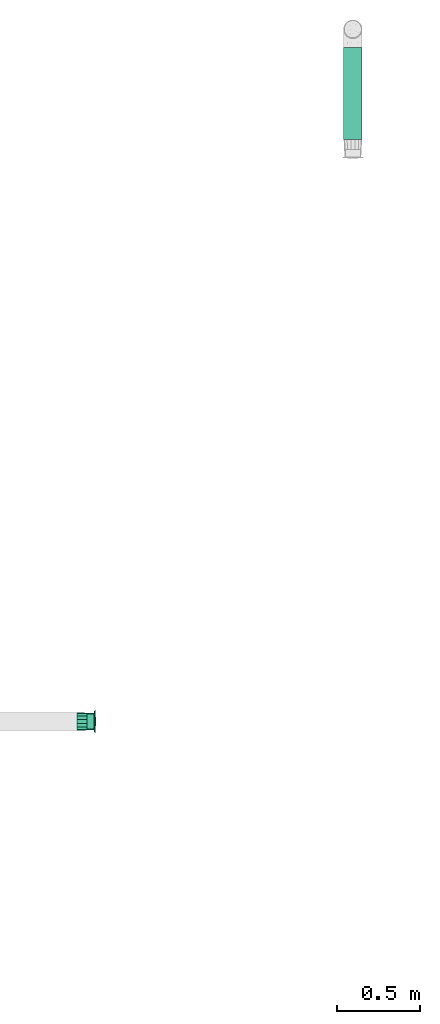
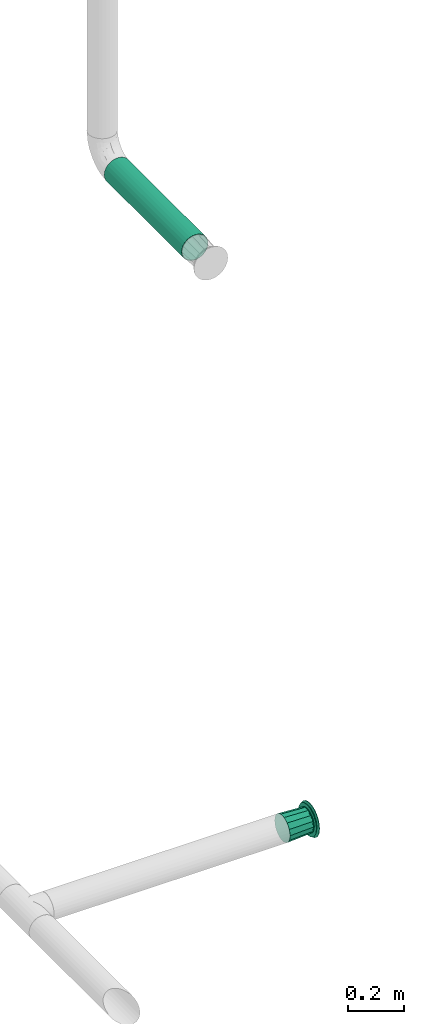
# One storey, part 110 of 115: 1 flow fitting, 1 flow segment, 1 flow terminal.
"""IFC2X3 building model written with IfcOpenShell, lengths in millimetres."""

import ifcopenshell
import ifcopenshell.guid

model = None  # the IFC model being written
_history = None  # IfcOwnerHistory: only IFC2X3 demands one
_inside = {}  # id of a spatial element -> (the spatial element, [elements in it])
_under = {}  # id of a project, library or spatial element -> (it, [spatial elements below it])
_declared = {}  # id of a project -> (the project, [libraries it declares])
_typed = {}  # id of a type object -> (the type object, [elements of that type])
_made_of = {}  # id of a material, layer set ... -> (it, [elements and type objects made of it])


def new_model(schema):
    """Start an empty IFC model of exactly this schema.

    Asked for "IFC4X3", IfcOpenShell would pick the latest addendum, in which some entities
    have other attributes; the version numbers below select the first issue.
    IFC2X3 requires an IfcOwnerHistory on every rooted entity: one is made here for all.
    """
    global model, _history
    if schema == "IFC4X3":
        model = ifcopenshell.file(schema_version=(4, 3, 0, 0))
    else:
        model = ifcopenshell.file(schema=schema)
    _inside.clear()
    _under.clear()
    _declared.clear()
    _typed.clear()
    _made_of.clear()
    _history = None
    if model.schema == "IFC2X3":
        org = make("IfcOrganization", Name="unknown")
        user = make(
            "IfcPersonAndOrganization",
            ThePerson=make("IfcPerson", FamilyName="unknown"),
            TheOrganization=org,
        )
        app = make(
            "IfcApplication",
            ApplicationDeveloper=org,
            Version="unknown",
            ApplicationFullName="unknown",
            ApplicationIdentifier="unknown",
        )
        _history = make(
            "IfcOwnerHistory",
            OwningUser=user,
            OwningApplication=app,
            ChangeAction="ADDED",
            CreationDate=0,
        )
    return model


def make(cls, **values):
    """One entity of the class cls with the attributes given. An attribute that is None is left unset."""
    return model.create_entity(
        cls, **{name: value for name, value in values.items() if value is not None}
    )


def entity(cls, *values):
    """Any entity or typed value of the class cls, its attributes in the order of the schema. None: left unset."""
    e = model.create_entity(cls)
    for i, value in enumerate(values):
        if value is not None:
            e[i] = value
    return e


def rooted(cls, **values):
    """An entity with a GlobalId (a new one), such as an element, a storey or a relation."""
    return make(cls, GlobalId=ifcopenshell.guid.new(), OwnerHistory=_history, **values)


def si_unit(unit_type, name, prefix=None):
    """IfcSIUnit, for example si_unit("LENGTHUNIT", "METRE", prefix="MILLI")."""
    return make("IfcSIUnit", UnitType=unit_type, Prefix=prefix, Name=name)


def converted_unit(unit_type, name, factor, base, dimensions=None, offset=None):
    """IfcConversionBasedUnit, such as the inch: factor (a typed value) times the base unit."""
    return make(
        "IfcConversionBasedUnit"
        if offset is None
        else "IfcConversionBasedUnitWithOffset",
        ConversionOffset=offset,
        Dimensions=None
        if dimensions is None
        else entity("IfcDimensionalExponents", *dimensions),
        UnitType=unit_type,
        Name=name,
        ConversionFactor=make(
            "IfcMeasureWithUnit", ValueComponent=factor, UnitComponent=base
        ),
    )


def derived_unit(unit_type, elements):
    """IfcDerivedUnit: a product of units, each with its exponent."""
    return make(
        "IfcDerivedUnit",
        Elements=[
            make("IfcDerivedUnitElement", Unit=unit, Exponent=power)
            for unit, power in elements
        ],
        UnitType=unit_type,
    )


def assignment(units):
    """IfcUnitAssignment: the units of a project."""
    return None if units is None else make("IfcUnitAssignment", Units=units)


def point(xyz):
    """IfcCartesianPoint."""
    return None if xyz is None else make("IfcCartesianPoint", Coordinates=xyz)


def direction(xyz):
    """IfcDirection."""
    return None if xyz is None else make("IfcDirection", DirectionRatios=xyz)


def frame(location, z_axis=None, x_axis=None):
    """IfcAxis2Placement3D, a coordinate frame: its origin and axes. An axis left out is left unset."""
    return make(
        "IfcAxis2Placement3D",
        Location=point(location),
        Axis=direction(z_axis),
        RefDirection=direction(x_axis),
    )


def frame_2d(location, x_axis=None):
    """IfcAxis2Placement2D, a coordinate frame in the plane: its origin and x axis."""
    return make(
        "IfcAxis2Placement2D", Location=point(location), RefDirection=direction(x_axis)
    )


def origin_with_axes():
    """The frame at (0, 0, 0) with the z axis (0, 0, 1) and the x axis (1, 0, 0) written out."""
    return frame((0.0, 0.0, 0.0), z_axis=(0.0, 0.0, 1.0), x_axis=(1.0, 0.0, 0.0))


def origin_2d_with_axis():
    """The frame at (0, 0) in the plane with the x axis (1, 0) written out."""
    return frame_2d((0.0, 0.0), x_axis=(1.0, 0.0))


def place(relative_to, where):
    """IfcLocalPlacement: puts the frame where relative to a parent placement (None: the world)."""
    return make(
        "IfcLocalPlacement", PlacementRelTo=relative_to, RelativePlacement=where
    )


def context(
    kind, dimensions, precision=None, world=None, true_north=None, identifier=None
):
    """IfcGeometricRepresentationContext, for example the 3D "Model" context."""
    return make(
        "IfcGeometricRepresentationContext",
        ContextIdentifier=identifier,
        ContextType=kind,
        CoordinateSpaceDimension=dimensions,
        Precision=precision,
        WorldCoordinateSystem=world,
        TrueNorth=true_north,
    )


def subcontext(parent, identifier, kind, view, scale=None):
    """IfcGeometricRepresentationSubContext, for example "Body" below "Model"."""
    return make(
        "IfcGeometricRepresentationSubContext",
        ContextIdentifier=identifier,
        ContextType=kind,
        ParentContext=parent,
        TargetScale=scale,
        TargetView=view,
    )


def project(units=None, contexts=None):
    """IfcProject with its units and contexts."""
    return rooted(
        "IfcProject",
        Name="project",
        RepresentationContexts=contexts,
        UnitsInContext=assignment(units),
    )


def spatial(cls, under=None, at=None, **own):
    """A site, building, storey or space (cls), placed at a placement, below another one or the project."""
    s = rooted(cls, ObjectPlacement=at, **own)
    if under is not None:
        _under.setdefault(under.id(), (under, []))[1].append(s)
    return s


def profile(cls, at=None, kind="AREA", **sizes):
    """A parametric profile (cls). Its sizes go by their IFC names, for example OverallWidth=200.0."""
    return make(cls, ProfileType=kind, Position=at, **sizes)


def hollow_circle(**sizes):
    """IfcCircleHollowProfileDef."""
    return profile("IfcCircleHollowProfileDef", **sizes)


def extrude(swept, where, along, depth):
    """IfcExtrudedAreaSolid: the profile swept, set in the frame where, extruded along a direction by depth."""
    return make(
        "IfcExtrudedAreaSolid",
        SweptArea=swept,
        Position=where,
        ExtrudedDirection=direction(along),
        Depth=depth,
    )


def faces_of(points, faces, orient=None, outer=None):
    """IfcFace entities. A face is a list of loops; a loop is a list of indices into points, from 0.

    orient and outer hold one flag for each loop. By default every Orientation is true, the
    first loop of a face is its IfcFaceOuterBound and the others are IfcFaceBound.
    """
    made = []
    for i, loops in enumerate(faces):
        bounds = []
        for j, loop in enumerate(loops):
            is_outer = j == 0 if outer is None else outer[i][j]
            bounds.append(
                make(
                    "IfcFaceOuterBound" if is_outer else "IfcFaceBound",
                    Bound=make("IfcPolyLoop", Polygon=[points[k] for k in loop]),
                    Orientation=True if orient is None else orient[i][j],
                )
            )
        made.append(make("IfcFace", Bounds=bounds))
    return made


def open_shell(faces, orient=None, outer=None):
    """The faces of one IfcOpenShell. surface_model builds it on its shared points."""
    return ("IfcOpenShell", faces, orient, outer)


def surface_model(cls, points, shells):
    """IfcFaceBasedSurfaceModel or IfcShellBasedSurfaceModel (cls): surfaces that need not close."""
    shared = [point(p) for p in points]
    made = [make(c, CfsFaces=faces_of(shared, fs, o, b)) for c, fs, o, b in shells]
    if cls == "IfcFaceBasedSurfaceModel":
        return make(cls, FbsmFaces=made)
    return make(cls, SbsmBoundary=made)


def shape(context_of_items, identifier, shape_type, items):
    """IfcShapeRepresentation: the items that make up one representation, for example the "Body"."""
    return make(
        "IfcShapeRepresentation",
        ContextOfItems=context_of_items,
        RepresentationIdentifier=identifier,
        RepresentationType=shape_type,
        Items=items,
    )


def source(mapping_origin, context_of_items, identifier, shape_type, items):
    """IfcRepresentationMap: a shape defined once, which mapped items show again and again."""
    return make(
        "IfcRepresentationMap",
        MappingOrigin=mapping_origin,
        MappedRepresentation=shape(context_of_items, identifier, shape_type, items),
    )


def transform(
    local_origin,
    x_axis=None,
    y_axis=None,
    z_axis=None,
    scale=None,
    scale2=None,
    scale3=None,
    uniform=True,
):
    """IfcCartesianTransformationOperator3D, or its non-uniform kind. x_axis, y_axis, z_axis: its Axis1, 2, 3."""
    if uniform:
        return make(
            "IfcCartesianTransformationOperator3D",
            Axis1=direction(x_axis),
            Axis2=direction(y_axis),
            LocalOrigin=point(local_origin),
            Scale=scale,
            Axis3=direction(z_axis),
        )
    return make(
        "IfcCartesianTransformationOperator3DnonUniform",
        Axis1=direction(x_axis),
        Axis2=direction(y_axis),
        LocalOrigin=point(local_origin),
        Scale=scale,
        Axis3=direction(z_axis),
        Scale2=scale2,
        Scale3=scale3,
    )


def mapped(mapping_source, mapping_target):
    """IfcMappedItem: shows the shape of a source again, moved by a transform."""
    return make(
        "IfcMappedItem", MappingSource=mapping_source, MappingTarget=mapping_target
    )


def material(Name=None, Category=None):
    """IfcMaterial."""
    return make("IfcMaterial", Name=Name, Category=Category)


def layer(
    of_material, thickness, ventilated=None, Name=None, Category=None, Priority=None
):
    """IfcMaterialLayer: one layer of a wall or slab, of a material (None: an air gap)."""
    return make(
        "IfcMaterialLayer",
        Material=of_material,
        LayerThickness=thickness,
        IsVentilated=ventilated,
        Name=Name,
        Category=Category,
        Priority=Priority,
    )


def layer_set(layers, Name=None):
    """IfcMaterialLayerSet."""
    return make("IfcMaterialLayerSet", MaterialLayers=layers, LayerSetName=Name)


def layer_usage(for_layer_set, set_direction, sense, offset, extent=None):
    """IfcMaterialLayerSetUsage: how a layer set lies in its element."""
    return make(
        "IfcMaterialLayerSetUsage",
        ForLayerSet=for_layer_set,
        LayerSetDirection=set_direction,
        DirectionSense=sense,
        OffsetFromReferenceLine=offset,
        ReferenceExtent=extent,
    )


def made_of(thing, what):
    """Note that an element or type object is made of a material, layer set ...; save() writes the relation."""
    if what is not None:
        _made_of.setdefault(what.id(), (what, []))[1].append(thing)
    return thing


def type_object(cls, material=None, **own):
    """A type object (cls), such as IfcWallType, which elements share."""
    return made_of(rooted(cls, **own), material)


def element(
    cls,
    number,
    at=None,
    inside=None,
    cuts=None,
    type_object=None,
    material=None,
    context=None,
    identifier="Body",
    shape_type=None,
    held_by="IfcProductDefinitionShape",
    body=None,
    shapes=None,
    **own,
):
    """One element of the class cls, such as IfcWall. Its Tag is "e" and its number.

    at: its placement. inside: the storey or other place that contains it. cuts: it is an
    opening in that element (IfcRelVoidsElement). A single representation is given by context,
    identifier, shape_type and body (its items); several are given by shapes. held_by: the class
    of the entity that holds the representations. save() writes the other relations.
    """
    e = rooted(cls, Tag="e%d" % number, ObjectPlacement=at, **own)
    if body is not None:
        shapes = [shape(context, identifier, shape_type, body)]
    if shapes is not None:
        e.Representation = make(held_by, Representations=shapes)
    if inside is not None:
        _inside.setdefault(inside.id(), (inside, []))[1].append(e)
    if cuts is not None:
        rooted(
            "IfcRelVoidsElement", RelatingBuildingElement=cuts, RelatedOpeningElement=e
        )
    if type_object is not None:
        _typed.setdefault(type_object.id(), (type_object, []))[1].append(e)
    return made_of(e, material)


def aggregate(whole, parts):
    """IfcRelAggregates: a whole, such as a stair, and the parts it consists of."""
    return rooted("IfcRelAggregates", RelatingObject=whole, RelatedObjects=parts)


def save(model, path):
    """Write the relations noted so far, then the file.

    IfcRelAggregates (storeys below a building ...), IfcRelContainedInSpatialStructure (elements
    in a storey), IfcRelDefinesByType, IfcRelAssociatesMaterial and IfcRelDeclares: one each for
    every whole, place, type object, material and project.
    """
    for whole, parts in _under.values():
        aggregate(whole, parts)
    for where, things in _inside.values():
        rooted(
            "IfcRelContainedInSpatialStructure",
            RelatedElements=things,
            RelatingStructure=where,
        )
    for kind, things in _typed.values():
        rooted("IfcRelDefinesByType", RelatedObjects=things, RelatingType=kind)
    for what, things in _made_of.values():
        rooted("IfcRelAssociatesMaterial", RelatedObjects=things, RelatingMaterial=what)
    for by, libraries in _declared.values():
        rooted("IfcRelDeclares", RelatingContext=by, RelatedDefinitions=libraries)
    model.write(path)


model = new_model("IFC2X3")

# Units and contexts
model_context = context("Model", 3, precision=1e-05, world=origin_with_axes(), true_north=direction((0.0, 1.0)))
body_context = subcontext(model_context, "Body", "Model", "MODEL_VIEW")
ifc_project = project(units=[si_unit("AREAUNIT", "SQUARE_METRE"), si_unit("VOLUMEUNIT", "CUBIC_METRE", prefix="DECI"), si_unit("TIMEUNIT", "SECOND"), si_unit("THERMODYNAMICTEMPERATUREUNIT", "DEGREE_CELSIUS"), si_unit("PRESSUREUNIT", "PASCAL"), si_unit("MASSUNIT", "GRAM", prefix="KILO"), si_unit("LENGTHUNIT", "METRE", prefix="MILLI"), si_unit("POWERUNIT", "WATT"), si_unit("ELECTRICCURRENTUNIT", "AMPERE"), si_unit("ELECTRICVOLTAGEUNIT", "VOLT"), derived_unit("VOLUMETRICFLOWRATEUNIT", [(si_unit("VOLUMEUNIT", "CUBIC_METRE", prefix="DECI"), 1), (si_unit("TIMEUNIT", "SECOND"), -1)]), derived_unit("LINEARVELOCITYUNIT", [(si_unit("LENGTHUNIT", "METRE"), 1), (si_unit("TIMEUNIT", "SECOND"), -1)]), derived_unit("MASSDENSITYUNIT", [(si_unit("MASSUNIT", "GRAM", prefix="KILO"), 1), (si_unit("VOLUMEUNIT", "CUBIC_METRE"), -1)]), converted_unit("PLANEANGLEUNIT", "DEGREE", entity("IfcRatioMeasure", 0.01745), si_unit("PLANEANGLEUNIT", "RADIAN"), dimensions=[0, 0, 0, 0, 0, 0, 0])], contexts=[model_context])

# Site, building, storey
site_placement = place(None, origin_with_axes())
site = spatial("IfcSite", under=ifc_project, at=site_placement, CompositionType="ELEMENT")
building_placement = place(site_placement, origin_with_axes())
building = spatial("IfcBuilding", under=site, at=building_placement, Name="mc-building", CompositionType="ELEMENT")
storey_placement = place(building_placement, frame((0.0, 0.0, 2950.0), z_axis=(0.0, 0.0, 1.0), x_axis=(1.0, 0.0, 0.0)))
storey = spatial("IfcBuildingStorey", under=building, at=storey_placement, Name="2. Korrus", CompositionType="ELEMENT", Elevation=2950.0)

# Flow terminal
air_terminal_type = type_object("IfcAirTerminalType", Name="100", PredefinedType="NOTDEFINED")
shared_shape_1 = source(origin_with_axes(), body_context, "Body", "SurfaceModel", [
    surface_model("IfcShellBasedSurfaceModel", [(11.2, -70.0, 0.0), (11.2, -67.61481, -18.11733), (11.2, -67.61481, 18.11733), (6.2, -14.64625, -20.15883), (9.2, -22.36867, -22.36867), (6.2, -21.19625, -15.39997), (9.2, 16.375, -28.36233), (6.2, 8.09625, -24.91768), (6.2, 14.64625, -20.15883), (6.2, -8.09625, -24.91768), (9.2, -16.375, -28.36233), (6.2, 21.19625, -15.39997), (9.2, 22.36867, -22.36867), (9.2, -8.1875, -30.55617), (9.2, 8.1875, -30.55617), (9.2, 28.36233, -16.375), (9.2, -28.36233, -16.375), (6.2, 14.64625, 20.15883), (9.2, 22.36867, 22.36867), (6.2, 21.19625, 15.39997), (9.2, -16.375, 28.36233), (6.2, -8.09625, 24.91768), (6.2, -14.64625, 20.15883), (6.2, 8.09625, 24.91768), (9.2, 16.375, 28.36233), (6.2, -21.19625, 15.39997), (9.2, -22.36867, 22.36867), (9.2, 8.1875, 30.55617), (9.2, -8.1875, 30.55617), (9.2, -28.36233, 16.375), (9.2, 28.36233, 16.375), (6.2, -53.11211, -25.57744), (6.2, -36.75472, -46.08897), (6.2, -13.11761, -57.472), (6.2, 13.11761, -57.472), (6.2, 36.75472, -46.08897), (6.2, 53.11211, -25.57744), (0.0, -12.53288, -63.00706), (6.2, 0.0, -57.472), (0.0, -46.3155, -46.3155), (0.0, -35.69063, -53.4148), (0.0, 0.0, -65.5), (6.2, 44.93342, -35.83321), (0.0, 46.3155, -46.3155), (0.0, 35.69063, -53.4148), (6.2, -44.93342, -35.83321), (0.0, 12.53288, -63.00706), (0.0, 25.06576, -60.51411), (6.2, 56.03105, -12.78872), (0.0, 60.51411, -25.06576), (0.0, 63.00706, -12.53288), (0.0, 53.4148, -35.69063), (0.0, -25.06576, -60.51411), (0.0, -63.00706, -12.53288), (0.0, -60.51411, -25.06576), (6.2, -56.03105, -12.78872), (0.0, -53.4148, -35.69063), (6.2, 13.11761, 57.472), (0.0, 12.53288, 63.00706), (6.2, 0.0, 57.472), (6.2, 36.75472, 46.08897), (0.0, 46.3155, 46.3155), (0.0, 35.69063, 53.4148), (0.0, 0.0, 65.5), (6.2, -44.93342, 35.83321), (6.2, -36.75472, 46.08897), (0.0, -46.3155, 46.3155), (0.0, -35.69063, 53.4148), (6.2, 44.93342, 35.83321), (0.0, -12.53288, 63.00706), (0.0, -25.06576, 60.51411), (6.2, -13.11761, 57.472), (6.2, -56.03105, 12.78872), (0.0, -60.51411, 25.06576), (0.0, -63.00706, 12.53288), (0.0, -53.4148, 35.69063), (0.0, 25.06576, 60.51411), (0.0, 63.00706, 12.53288), (0.0, 60.51411, 25.06576), (6.2, 56.03105, 12.78872), (0.0, 53.4148, 35.69063), (-3.1, 43.30127, 25.0), (-3.1, -48.29629, -12.94095), (-3.1, -43.30127, 25.0), (-3.1, 25.0, -43.30127), (-3.1, 48.29629, -12.94095), (-3.1, 35.35534, -35.35534), (-3.1, -35.35534, -35.35534), (-3.1, -25.0, -43.30127), (-43.1, 43.46666, 11.64686), (-3.1, 38.97115, 22.5), (-3.1, 43.46666, 11.64686), (-3.1, 45.0, 0.0), (-43.1, 45.0, 0.0), (-3.1, 31.81981, 31.81981), (-43.1, 38.97115, 22.5), (-43.1, -38.97115, 22.5), (-3.1, -38.97115, 22.5), (-3.1, -31.81981, 31.81981), (-3.1, -43.46666, 11.64686), (-43.1, -43.46666, 11.64686), (-43.1, -45.0, 0.0), (-3.1, -45.0, 0.0), (-43.1, -43.46666, -11.64686), (-3.1, -38.97115, -22.5), (-3.1, -43.46666, -11.64686), (-3.1, -11.64686, -43.46666), (-3.1, -22.5, -38.97115), (-43.1, -22.5, -38.97115), (-3.1, -31.81981, -31.81981), (-43.1, -38.97115, -22.5), (-43.1, 22.5, -38.97115), (-3.1, 22.5, -38.97115), (-3.1, 11.64686, -43.46666), (-43.1, 38.97115, -22.5), (-3.1, 38.97115, -22.5), (-3.1, 31.81981, -31.81981), (-3.1, 43.46666, -11.64686), (-43.1, 43.46666, -11.64686), (11.2, -49.49747, -49.49747), (11.2, -35.0, -60.62178), (11.2, -18.11733, -67.61481), (11.2, 67.61481, 18.11733), (11.2, -60.62178, -35.0), (11.2, 18.11733, -67.61481), (11.2, 35.0, -60.62178), (11.2, 0.0, -70.0), (11.2, 60.62178, -35.0), (11.2, 67.61481, -18.11733), (11.2, 49.49747, -49.49747), (11.2, -49.49747, 49.49747), (11.2, -60.62178, 35.0), (11.2, -35.0, 60.62178), (11.2, -18.11733, 67.61481), (11.2, 0.0, 70.0), (11.2, 60.62178, 35.0), (11.2, 49.49747, 49.49747), (11.2, 70.0, 0.0), (11.2, 35.0, 60.62178), (11.2, 18.11733, 67.61481), (9.2, -49.49747, 49.49747), (9.2, -35.0, 60.62178), (9.2, -18.11733, 67.61481), (9.2, -67.61481, 18.11733), (9.2, -70.0, 0.0), (9.2, -60.62178, 35.0), (9.2, 67.61481, 18.11733), (9.2, 35.0, 60.62178), (9.2, 18.11733, 67.61481), (9.2, 0.0, 70.0), (9.2, 60.62178, 35.0), (9.2, 49.49747, 49.49747), (9.2, -67.61481, -18.11733), (9.2, -49.49747, -49.49747), (9.2, -60.62178, -35.0), (9.2, -18.11733, -67.61481), (9.2, 70.0, 0.0), (9.2, -35.0, -60.62178), (9.2, 0.0, -70.0), (9.2, 60.62178, -35.0), (9.2, 49.49747, -49.49747), (9.2, 67.61481, -18.11733), (9.2, 35.0, -60.62178), (9.2, 18.11733, -67.61481), (9.2, -32.75, 0.0), (9.2, 0.0, 32.75), (9.2, 32.75, 0.0), (9.2, 0.0, -32.75), (6.2, 26.2, 0.0), (6.2, -26.2, 0.0), (9.2, -31.06579, -6.28555), (6.2, -23.69812, -7.69999), (6.2, 23.69812, -7.69999), (9.2, 31.06579, -6.28555), (6.2, 0.0, -24.91768), (9.2, 31.06579, 6.28555), (6.2, 23.69812, 7.69999), (6.2, -23.69812, 7.69999), (9.2, -31.06579, 6.28555), (6.2, 0.0, 24.91768), (6.2, 53.11211, 25.57744), (6.2, 58.95, 0.0), (6.2, -53.11211, 25.57744), (6.2, -58.95, 0.0), (0.0, 65.5, 0.0), (0.0, -65.5, 0.0), (6.2, -24.93616, -51.78048), (6.2, 24.93616, -51.78048), (6.2, 24.93616, 51.78048), (6.2, -24.93616, 51.78048), (-3.1, 0.0, 50.0), (-3.1, 35.35534, 35.35534), (-3.1, -12.94095, 48.29629), (-3.1, -25.0, 43.30127), (-3.1, -35.35534, 35.35534), (-3.1, 25.0, 43.30127), (-3.1, 12.94095, 48.29629), (-3.1, 48.29629, 12.94095), (-3.1, 50.0, 0.0), (-3.1, -50.0, 0.0), (-3.1, -48.29629, 12.94095), (-3.1, -43.30127, -25.0), (-3.1, -12.94095, -48.29629), (-3.1, 0.0, -50.0), (-3.1, 43.30127, -25.0), (-3.1, 12.94095, -48.29629), (0.0, -12.94095, -48.29629), (0.0, 0.0, -50.0), (0.0, -25.0, -43.30127), (0.0, -35.35534, -35.35534), (0.0, -48.29629, -12.94095), (0.0, 25.0, -43.30127), (0.0, -43.30127, -25.0), (0.0, 43.30127, 25.0), (0.0, 12.94095, -48.29629), (0.0, 43.30127, -25.0), (0.0, 48.29629, -12.94095), (0.0, 35.35534, -35.35534), (0.0, 50.0, 0.0), (0.0, -50.0, 0.0), (0.0, -48.29629, 12.94095), (0.0, -43.30127, 25.0), (0.0, -35.35534, 35.35534), (0.0, -12.94095, 48.29629), (0.0, -25.0, 43.30127), (0.0, 35.35534, 35.35534), (0.0, 0.0, 50.0), (0.0, 48.29629, 12.94095), (0.0, 25.0, 43.30127), (0.0, 12.94095, 48.29629), (-43.1, -22.5, 38.97115), (-43.1, -11.64686, 43.46666), (-43.1, 0.0, 45.0), (-43.1, 11.64686, 43.46666), (-43.1, -31.81981, 31.81981), (-43.1, 31.81981, 31.81981), (-43.1, 22.5, 38.97115), (-43.1, -31.81981, -31.81981), (-43.1, 31.81981, -31.81981), (-43.1, -11.64686, -43.46666), (-43.1, 11.64686, -43.46666), (-43.1, 0.0, -45.0), (-3.1, 0.0, -45.0), (-3.1, 0.0, 45.0), (-3.1, -22.5, 38.97115), (-3.1, -11.64686, 43.46666), (-3.1, 11.64686, 43.46666), (-3.1, 22.5, 38.97115)], [open_shell([[[0, 1, 2]], [[3, 4, 5]], [[6, 7, 8]], [[3, 9, 10]], [[4, 3, 10]], [[11, 12, 8]], [[13, 10, 9]], [[7, 6, 14]], [[6, 8, 12]], [[12, 11, 15]], [[16, 5, 4]], [[17, 18, 19]], [[20, 21, 22]], [[17, 23, 24]], [[18, 17, 24]], [[25, 26, 22]], [[27, 24, 23]], [[21, 20, 28]], [[20, 22, 26]], [[26, 25, 29]], [[30, 19, 18]], [[31, 32, 33]], [[34, 35, 36]], [[33, 37, 38]], [[32, 39, 40]], [[41, 38, 37]], [[42, 35, 43]], [[44, 43, 35]], [[39, 32, 45]], [[46, 47, 34]], [[48, 49, 50]], [[38, 46, 34]], [[42, 43, 51]], [[33, 52, 37]], [[53, 54, 55]], [[46, 38, 41]], [[56, 39, 45]], [[57, 58, 59]], [[60, 61, 62]], [[63, 59, 58]], [[64, 65, 66]], [[67, 66, 65]], [[61, 60, 68]], [[69, 70, 71]], [[72, 73, 74]], [[59, 69, 71]], [[64, 66, 75]], [[57, 76, 58]], [[77, 78, 79]], [[69, 59, 63]], [[80, 61, 68]], [[81, 82, 83]], [[84, 85, 86]], [[87, 82, 88]], [[89, 90, 91]], [[91, 92, 93]], [[94, 90, 95]], [[96, 97, 98]], [[99, 97, 100]], [[101, 102, 99]], [[103, 104, 105]], [[105, 102, 101]], [[106, 107, 108]], [[109, 104, 110]], [[111, 112, 113]], [[114, 115, 116]], [[117, 115, 118]], [[93, 92, 117]], [[119, 120, 121]], [[1, 119, 121]], [[122, 1, 121]], [[123, 119, 1]], [[124, 122, 121]], [[125, 122, 124]], [[121, 126, 124]], [[127, 128, 129]], [[129, 128, 122]], [[129, 122, 125]], [[130, 131, 2]], [[132, 130, 2]], [[122, 133, 2]], [[132, 2, 133]], [[134, 133, 122]], [[135, 136, 122]], [[122, 128, 137]], [[136, 138, 122]], [[139, 122, 138]], [[122, 139, 134]], [[2, 1, 122]], [[140, 141, 142]], [[143, 140, 142]], [[142, 144, 143]], [[145, 140, 143]], [[146, 144, 142]], [[147, 146, 148]], [[149, 148, 146]], [[150, 146, 151]], [[147, 151, 146]], [[146, 142, 149]], [[146, 152, 144]], [[153, 154, 152]], [[155, 153, 152]], [[146, 156, 155]], [[157, 153, 155]], [[158, 155, 156]], [[159, 160, 161]], [[156, 161, 160]], [[160, 162, 156]], [[163, 156, 162]], [[163, 158, 156]], [[152, 146, 155]], [[156, 128, 161]], [[161, 127, 159]], [[162, 160, 125]], [[129, 160, 159]], [[163, 162, 124]], [[128, 127, 161]], [[156, 137, 128]], [[162, 125, 124]], [[125, 160, 129]], [[159, 127, 129]], [[163, 124, 126]], [[126, 158, 163]], [[158, 121, 155]], [[155, 120, 157]], [[154, 153, 123]], [[119, 153, 157]], [[152, 154, 1]], [[120, 119, 157]], [[155, 121, 120]], [[152, 1, 0]], [[1, 154, 123]], [[153, 119, 123]], [[152, 0, 144]], [[126, 121, 158]], [[144, 2, 143]], [[143, 131, 145]], [[141, 140, 132]], [[130, 140, 145]], [[142, 141, 133]], [[2, 131, 143]], [[144, 0, 2]], [[141, 132, 133]], [[132, 140, 130]], [[145, 131, 130]], [[142, 133, 134]], [[134, 149, 142]], [[149, 139, 148]], [[148, 138, 147]], [[150, 151, 135]], [[136, 151, 147]], [[146, 150, 122]], [[138, 136, 147]], [[148, 139, 138]], [[146, 122, 137]], [[122, 150, 135]], [[151, 136, 135]], [[146, 137, 156]], [[134, 139, 149]], [[30, 24, 164]], [[24, 20, 164]], [[165, 20, 24]], [[164, 20, 29]], [[166, 30, 16]], [[16, 6, 166]], [[167, 6, 10]], [[30, 164, 16]], [[10, 6, 16]], [[6, 15, 166]], [[21, 19, 11]], [[23, 19, 21]], [[11, 19, 168]], [[7, 25, 21]], [[7, 5, 169]], [[21, 11, 7]], [[9, 5, 7]], [[169, 25, 7]], [[170, 164, 169]], [[170, 171, 16]], [[11, 172, 15]], [[172, 168, 173]], [[174, 13, 9]], [[166, 173, 168]], [[172, 173, 15]], [[169, 171, 170]], [[5, 16, 171]], [[167, 174, 14]], [[174, 167, 13]], [[14, 174, 7]], [[175, 166, 168]], [[175, 176, 30]], [[25, 177, 29]], [[177, 169, 178]], [[179, 27, 23]], [[164, 178, 169]], [[177, 178, 29]], [[168, 176, 175]], [[19, 30, 176]], [[165, 179, 28]], [[179, 165, 27]], [[28, 179, 21]], [[180, 60, 57]], [[181, 180, 65]], [[65, 57, 71]], [[180, 57, 65]], [[65, 182, 181]], [[182, 36, 181]], [[183, 34, 36]], [[31, 34, 183]], [[31, 33, 34]], [[182, 183, 36]], [[70, 63, 49]], [[70, 73, 66]], [[49, 63, 184]], [[78, 76, 61]], [[76, 78, 184]], [[184, 63, 76]], [[73, 70, 49]], [[39, 54, 185]], [[41, 39, 185]], [[52, 39, 41]], [[43, 185, 49]], [[185, 43, 47]], [[185, 47, 41]], [[73, 49, 185]], [[55, 54, 31]], [[31, 54, 56]], [[52, 186, 40]], [[53, 55, 183]], [[56, 45, 31]], [[185, 53, 183]], [[32, 40, 186]], [[33, 186, 52]], [[44, 35, 187]], [[49, 36, 51]], [[34, 47, 187]], [[42, 51, 36]], [[187, 47, 44]], [[49, 48, 36]], [[48, 50, 181]], [[184, 181, 50]], [[79, 78, 180]], [[180, 78, 80]], [[76, 188, 62]], [[77, 79, 181]], [[80, 68, 180]], [[184, 77, 181]], [[60, 62, 188]], [[57, 188, 76]], [[67, 65, 189]], [[73, 182, 75]], [[71, 70, 189]], [[64, 75, 182]], [[189, 70, 67]], [[73, 72, 182]], [[72, 74, 183]], [[185, 183, 74]], [[190, 191, 192]], [[193, 192, 194]], [[83, 192, 81]], [[194, 192, 83]], [[195, 191, 196]], [[191, 190, 196]], [[197, 198, 81]], [[81, 192, 191]], [[198, 84, 81]], [[199, 200, 83]], [[81, 88, 82]], [[201, 82, 87]], [[88, 81, 202]], [[81, 203, 202]], [[204, 86, 85]], [[205, 203, 84]], [[84, 198, 85]], [[81, 84, 203]], [[199, 83, 82]], [[206, 207, 208]], [[209, 208, 210]], [[210, 208, 211]], [[212, 209, 210]], [[210, 211, 213]], [[214, 211, 207]], [[211, 208, 207]], [[215, 216, 217]], [[211, 217, 216]], [[216, 218, 211]], [[219, 210, 220]], [[221, 210, 213]], [[222, 221, 223]], [[213, 223, 221]], [[224, 222, 223]], [[223, 225, 226]], [[227, 213, 218]], [[218, 213, 211]], [[228, 229, 225]], [[223, 213, 225]], [[226, 225, 229]], [[221, 220, 210]], [[199, 220, 200]], [[200, 221, 83]], [[193, 194, 224]], [[222, 194, 83]], [[192, 193, 223]], [[220, 221, 200]], [[199, 219, 220]], [[193, 224, 223]], [[224, 194, 222]], [[83, 221, 222]], [[192, 223, 226]], [[226, 190, 192]], [[190, 229, 196]], [[196, 228, 195]], [[81, 191, 213]], [[225, 191, 195]], [[197, 81, 227]], [[228, 225, 195]], [[196, 229, 228]], [[197, 227, 218]], [[227, 81, 213]], [[191, 225, 213]], [[197, 218, 198]], [[226, 229, 190]], [[198, 216, 85]], [[85, 215, 204]], [[84, 86, 211]], [[217, 86, 204]], [[205, 84, 214]], [[216, 215, 85]], [[198, 218, 216]], [[84, 211, 214]], [[211, 86, 217]], [[204, 215, 217]], [[205, 214, 207]], [[207, 203, 205]], [[203, 206, 202]], [[202, 208, 88]], [[201, 87, 212]], [[209, 87, 88]], [[82, 201, 210]], [[208, 209, 88]], [[202, 206, 208]], [[82, 210, 219]], [[210, 201, 212]], [[87, 209, 212]], [[82, 219, 199]], [[207, 206, 203]], [[230, 231, 232]], [[230, 232, 233]], [[230, 100, 96]], [[234, 230, 96]], [[100, 230, 233]], [[235, 89, 236]], [[100, 233, 236]], [[95, 89, 235]], [[118, 89, 93]], [[118, 236, 89]], [[118, 100, 236]], [[110, 103, 101]], [[237, 110, 101]], [[238, 108, 101]], [[237, 101, 108]], [[239, 108, 238]], [[114, 238, 118]], [[238, 101, 118]], [[240, 241, 111]], [[238, 111, 241]], [[238, 241, 239]], [[100, 118, 101]], [[106, 242, 107]], [[107, 112, 109]], [[102, 105, 104]], [[112, 104, 109]], [[92, 104, 117]], [[113, 112, 242]], [[112, 107, 242]], [[115, 117, 116]], [[112, 116, 117]], [[112, 117, 104]], [[92, 102, 104]], [[97, 99, 243]], [[98, 97, 244]], [[243, 245, 244]], [[97, 243, 244]], [[246, 243, 99]], [[90, 94, 91]], [[92, 91, 247]], [[94, 247, 91]], [[247, 99, 92]], [[247, 246, 99]], [[102, 92, 99]], [[101, 99, 100]], [[100, 97, 96]], [[230, 234, 244]], [[98, 234, 96]], [[231, 230, 245]], [[245, 230, 244]], [[244, 234, 98]], [[245, 243, 231]], [[243, 232, 231]], [[236, 233, 246]], [[236, 247, 235]], [[89, 95, 90]], [[94, 95, 235]], [[93, 89, 91]], [[232, 246, 233]], [[246, 247, 236]], [[243, 246, 232]], [[247, 94, 235]], [[93, 117, 118]], [[118, 115, 114]], [[111, 238, 112]], [[116, 238, 114]], [[240, 111, 113]], [[112, 238, 116]], [[240, 113, 242]], [[242, 241, 240]], [[108, 239, 106]], [[108, 107, 237]], [[103, 110, 104]], [[109, 110, 237]], [[101, 103, 105]], [[241, 106, 239]], [[242, 106, 241]], [[107, 109, 237]]])]),
])
flow_terminal_placement = place(storey_placement, frame((35169.04693, 9505.0, 2465.0), z_axis=(0.0, 0.0, 1.0), x_axis=(1.0, 0.0, 0.0)))
element("IfcFlowTerminal", 1, at=flow_terminal_placement, inside=storey, type_object=air_terminal_type, Name="100", context=body_context, shape_type="MappedRepresentation", body=[
    mapped(shared_shape_1, transform((0.0, 0.0, 0.0), scale=1.0)),
])

# Flow fitting
duct_fitting_type = type_object("IfcDuctFittingType", PredefinedType="TRANSITION")
shared_shape_2 = source(origin_with_axes(), body_context, "Body", "SurfaceModel", [
    surface_model("IfcShellBasedSurfaceModel", [(100.0, -55.0, 0.0), (100.0, -12.23865, 53.62104), (100.0, -34.29194, 43.00073), (100.0, 49.55329, 23.86361), (100.0, 34.29194, 43.00073), (100.0, 49.55329, -23.86361), (0.0, -45.04844, -21.69419), (0.0, -50.0, 0.0), (0.0, -45.04844, 21.69419), (0.0, 31.17449, 39.09157), (0.0, 45.04844, 21.69419), (0.0, 50.0, 0.0), (98.0, 47.63139, 27.5), (98.0, 0.0, 55.0), (98.0, 38.89087, 38.89087), (98.0, -38.89087, 38.89087), (98.0, -47.63139, 27.5), (100.0, 12.23865, 53.62104), (100.0, -49.55329, 23.86361), (100.0, 55.0, 0.0), (100.0, 12.23865, -53.62104), (100.0, 34.29194, -43.00073), (100.0, -49.55329, -23.86361), (100.0, -34.29194, -43.00073), (100.0, -12.23865, -53.62104), (0.0, -31.17449, 39.09157), (0.0, -11.12605, 48.7464), (0.0, 11.12605, 48.7464), (0.0, -31.17449, -39.09157), (0.0, 11.12605, -48.7464), (0.0, -11.12605, -48.7464), (0.0, 45.04844, -21.69419), (0.0, 31.17449, -39.09157), (0.0, 47.52422, -10.84709), (0.0, 38.11147, -30.39288), (100.0, 41.92261, -33.43217), (100.0, -41.92261, -33.43217), (0.0, -38.11147, -30.39288), (100.0, 23.2653, -48.31088), (0.0, 21.15027, -43.91899), (100.0, 52.32388, -11.72483), (0.0, 0.0, -48.7464), (100.0, 0.0, -53.62104), (0.0, -21.15027, -43.91899), (100.0, -23.2653, -48.31088), (0.0, -47.52422, -10.84709), (100.0, -52.32388, -11.72483), (0.0, -47.52422, 10.84709), (0.0, -38.11147, 30.39288), (100.0, -41.92261, 33.43217), (100.0, 41.92261, 33.43217), (0.0, 38.11147, 30.39288), (100.0, -23.2653, 48.31088), (0.0, -21.15027, 43.91899), (100.0, -52.32388, 11.72483), (0.0, 0.0, 48.7464), (100.0, 0.0, 53.62104), (0.0, 21.15027, 43.91899), (100.0, 23.2653, 48.31088), (0.0, 47.52422, 10.84709), (100.0, 52.32388, 11.72483), (100.0, -14.23505, -53.12592), (100.0, 0.0, -55.0), (100.0, -27.5, -47.63139), (100.0, 27.5, -47.63139), (100.0, -38.89087, -38.89087), (100.0, -53.12592, -14.23505), (100.0, -47.63139, -27.5), (100.0, -47.63139, 27.5), (100.0, 14.23505, -53.12592), (100.0, 38.89087, -38.89087), (100.0, 47.63139, -27.5), (100.0, 47.63139, 27.5), (100.0, 53.12592, -14.23505), (100.0, -53.12592, 14.23505), (100.0, -38.89087, 38.89087), (100.0, -27.5, 47.63139), (100.0, 0.0, 55.0), (100.0, -14.23505, 53.12592), (100.0, 53.12592, 14.23505), (100.0, 38.89087, 38.89087), (100.0, 27.5, 47.63139), (100.0, 14.23505, 53.12592), (98.0, -27.5, 47.63139), (98.0, -14.23505, 53.12592), (98.0, -53.12592, -14.23505), (98.0, 14.23505, 53.12592), (98.0, 27.5, 47.63139), (98.0, 53.12592, 14.23505), (98.0, 55.0, 0.0), (98.0, -47.63139, -27.5), (98.0, -53.12592, 14.23505), (98.0, 27.5, -47.63139), (98.0, -27.5, -47.63139), (98.0, -38.89087, -38.89087), (98.0, 0.0, -55.0), (98.0, -14.23505, -53.12592), (98.0, 38.89087, -38.89087), (98.0, 47.63139, -27.5), (98.0, 53.12592, -14.23505), (98.0, 14.23505, -53.12592), (98.0, -55.0, 0.0), (0.0, 0.0, 50.0), (0.0, 35.35534, 35.35534), (0.0, -12.94095, 48.29629), (0.0, -25.0, 43.30127), (0.0, -35.35534, 35.35534), (0.0, -48.29629, 12.94095), (0.0, -43.30127, 25.0), (0.0, 25.0, 43.30127), (0.0, 12.94095, 48.29629), (0.0, 43.30127, 25.0), (0.0, 48.29629, 12.94095), (0.0, 25.0, -43.30127), (0.0, 48.29629, -12.94095), (0.0, -48.29629, -12.94095), (0.0, -43.30127, -25.0), (0.0, -12.94095, -48.29629), (0.0, -25.0, -43.30127), (0.0, -35.35534, -35.35534), (0.0, 43.30127, -25.0), (0.0, 35.35534, -35.35534), (0.0, 12.94095, -48.29629), (0.0, 0.0, -50.0), (2.0, -35.35534, -35.35534), (2.0, -25.0, -43.30127), (2.0, -12.94095, -48.29629), (2.0, -43.30127, -25.0), (2.0, 0.0, -50.0), (2.0, -48.29629, -12.94095), (2.0, -50.0, 0.0), (2.0, 12.94095, -48.29629), (2.0, 25.0, -43.30127), (2.0, 43.30127, -25.0), (2.0, 48.29629, -12.94095), (2.0, 35.35534, -35.35534), (2.0, -48.29629, 12.94095), (2.0, -35.35534, 35.35534), (2.0, -43.30127, 25.0), (2.0, 35.35534, 35.35534), (2.0, -12.94095, 48.29629), (2.0, -25.0, 43.30127), (2.0, 0.0, 50.0), (2.0, 43.30127, 25.0), (2.0, 48.29629, 12.94095), (2.0, 50.0, 0.0), (2.0, 25.0, 43.30127), (2.0, 12.94095, 48.29629)], [open_shell([[[0, 1, 2]], [[3, 4, 5]], [[6, 7, 8]], [[9, 10, 11]], [[12, 13, 14]], [[15, 13, 16]], [[0, 4, 17]], [[2, 18, 0]], [[1, 0, 17]], [[3, 5, 19]], [[20, 21, 5]], [[22, 20, 5]], [[22, 5, 0]], [[22, 23, 24]], [[22, 24, 20]], [[4, 0, 5]], [[8, 25, 6]], [[6, 25, 26]], [[6, 26, 27]], [[11, 27, 9]], [[28, 6, 29]], [[30, 28, 29]], [[31, 6, 11]], [[31, 32, 29]], [[31, 29, 6]], [[27, 11, 6]], [[31, 33, 5]], [[34, 35, 32]], [[36, 22, 6]], [[36, 37, 23]], [[38, 29, 39]], [[33, 40, 5]], [[33, 11, 40]], [[19, 40, 11]], [[32, 21, 39]], [[32, 35, 21]], [[34, 31, 35]], [[30, 41, 42]], [[28, 43, 44]], [[42, 41, 20]], [[7, 45, 46]], [[38, 39, 21]], [[46, 0, 7]], [[6, 37, 36]], [[38, 20, 29]], [[43, 30, 24]], [[42, 24, 30]], [[28, 23, 37]], [[6, 22, 45]], [[35, 31, 5]], [[44, 43, 24]], [[20, 41, 29]], [[46, 45, 22]], [[44, 23, 28]], [[8, 47, 18]], [[48, 49, 25]], [[50, 3, 10]], [[50, 51, 4]], [[52, 26, 53]], [[47, 54, 18]], [[47, 7, 54]], [[0, 54, 7]], [[25, 2, 53]], [[25, 49, 2]], [[48, 8, 49]], [[27, 55, 56]], [[9, 57, 58]], [[56, 55, 1]], [[11, 59, 60]], [[52, 53, 2]], [[60, 19, 11]], [[10, 51, 50]], [[52, 1, 26]], [[57, 27, 17]], [[56, 17, 27]], [[9, 4, 51]], [[10, 3, 59]], [[49, 8, 18]], [[58, 57, 17]], [[1, 55, 26]], [[60, 59, 3]], [[58, 4, 9]], [[61, 62, 63]], [[63, 64, 65]], [[66, 67, 68]], [[65, 64, 67]], [[67, 64, 68]], [[69, 64, 62]], [[64, 63, 62]], [[70, 71, 64]], [[72, 64, 71]], [[71, 73, 19]], [[74, 0, 66]], [[72, 68, 64]], [[75, 68, 76]], [[77, 78, 76]], [[72, 76, 68]], [[76, 72, 77]], [[79, 72, 19]], [[19, 72, 71]], [[80, 81, 77]], [[77, 72, 80]], [[82, 77, 81]], [[74, 66, 68]], [[83, 84, 13]], [[15, 83, 13]], [[12, 16, 13]], [[16, 12, 85]], [[86, 87, 13]], [[87, 14, 13]], [[88, 89, 12]], [[89, 90, 12]], [[91, 16, 85]], [[90, 85, 12]], [[89, 92, 90]], [[93, 94, 95]], [[95, 94, 90]], [[96, 93, 95]], [[97, 92, 98]], [[98, 89, 99]], [[100, 95, 92]], [[92, 89, 98]], [[90, 92, 95]], [[101, 91, 85]], [[89, 73, 99]], [[99, 71, 98]], [[92, 97, 64]], [[70, 97, 98]], [[100, 92, 69]], [[73, 71, 99]], [[89, 19, 73]], [[92, 64, 69]], [[64, 97, 70]], [[98, 71, 70]], [[100, 69, 62]], [[62, 95, 100]], [[95, 61, 96]], [[96, 63, 93]], [[90, 94, 67]], [[65, 94, 93]], [[85, 90, 66]], [[63, 65, 93]], [[96, 61, 63]], [[85, 66, 0]], [[66, 90, 67]], [[94, 65, 67]], [[85, 0, 101]], [[62, 61, 95]], [[101, 74, 91]], [[91, 68, 16]], [[83, 15, 76]], [[75, 15, 16]], [[84, 83, 78]], [[74, 68, 91]], [[101, 0, 74]], [[83, 76, 78]], [[76, 15, 75]], [[16, 68, 75]], [[84, 78, 77]], [[77, 13, 84]], [[13, 82, 86]], [[86, 81, 87]], [[12, 14, 72]], [[80, 14, 87]], [[88, 12, 79]], [[81, 80, 87]], [[86, 82, 81]], [[88, 79, 19]], [[79, 12, 72]], [[14, 80, 72]], [[88, 19, 89]], [[77, 82, 13]], [[102, 103, 104]], [[105, 104, 106]], [[107, 108, 106]], [[103, 106, 104]], [[106, 103, 107]], [[109, 103, 110]], [[103, 102, 110]], [[111, 112, 103]], [[113, 103, 112]], [[112, 11, 114]], [[107, 103, 113]], [[113, 115, 107]], [[116, 115, 117]], [[117, 118, 119]], [[116, 117, 119]], [[117, 115, 113]], [[120, 121, 114]], [[113, 114, 121]], [[113, 122, 117]], [[113, 112, 114]], [[117, 122, 123]], [[7, 107, 115]], [[124, 125, 126]], [[127, 124, 126]], [[128, 129, 126]], [[127, 126, 129]], [[130, 129, 128]], [[131, 132, 128]], [[132, 130, 128]], [[133, 134, 135]], [[132, 135, 134]], [[132, 134, 130]], [[134, 136, 130]], [[137, 138, 136]], [[137, 136, 139]], [[140, 137, 139]], [[141, 137, 140]], [[142, 140, 139]], [[143, 139, 144]], [[144, 134, 145]], [[146, 147, 139]], [[139, 136, 144]], [[139, 147, 142]], [[136, 134, 144]], [[11, 134, 114]], [[114, 133, 120]], [[113, 121, 132]], [[135, 121, 120]], [[122, 113, 131]], [[134, 133, 114]], [[11, 145, 134]], [[113, 132, 131]], [[132, 121, 135]], [[120, 133, 135]], [[122, 131, 128]], [[128, 123, 122]], [[123, 126, 117]], [[117, 125, 118]], [[116, 119, 127]], [[124, 119, 118]], [[115, 116, 129]], [[125, 124, 118]], [[117, 126, 125]], [[115, 129, 130]], [[129, 116, 127]], [[119, 124, 127]], [[115, 130, 7]], [[128, 126, 123]], [[7, 136, 107]], [[107, 138, 108]], [[105, 106, 141]], [[137, 106, 108]], [[104, 105, 140]], [[136, 138, 107]], [[7, 130, 136]], [[105, 141, 140]], [[141, 106, 137]], [[108, 138, 137]], [[104, 140, 142]], [[142, 102, 104]], [[102, 147, 110]], [[110, 146, 109]], [[111, 103, 143]], [[139, 103, 109]], [[112, 111, 144]], [[146, 139, 109]], [[110, 147, 146]], [[112, 144, 145]], [[144, 111, 143]], [[103, 139, 143]], [[112, 145, 11]], [[142, 147, 102]]])]),
])
flow_fitting_placement = place(storey_placement, frame((35165.94693, 9505.0, 2465.0), z_axis=(0.0, 0.0, 1.0), x_axis=(-1.0, 0.0, 0.0)))
element("IfcFlowFitting", 2, at=flow_fitting_placement, inside=storey, type_object=duct_fitting_type, context=body_context, shape_type="MappedRepresentation", body=[
    mapped(shared_shape_2, transform((0.0, 0.0, 0.0), scale=1.0)),
])

# Flow segment
ifc_material = material(Name="FZ1")
ifc_layer = layer(ifc_material, 0.0)
ifc_layer_set = layer_set([ifc_layer], Name="FZ1")
ifc_layer_usage = layer_usage(ifc_layer_set, "AXIS1", "POSITIVE", 0.0)
duct_segment_type = type_object("IfcDuctSegmentType", PredefinedType="RIGIDSEGMENT")
shared_shape_3 = source(origin_with_axes(), body_context, "Body", "SweptSolid", [
    extrude(hollow_circle(Radius=55.0, WallThickness=2.0, at=origin_2d_with_axis()), frame((0.0, 0.0, 0.0), z_axis=(1.0, 0.0, 0.0), x_axis=(0.0, 1.0, 0.0)), (0.0, 0.0, 1.0), 553.6),
])
flow_segment_placement = place(storey_placement, frame((36722.77222, 13000.0, 2300.0), z_axis=(0.0, 0.0, 1.0), x_axis=(0.0, 1.0, 0.0)))
element("IfcFlowSegment", 3, at=flow_segment_placement, inside=storey, type_object=duct_segment_type, material=ifc_layer_usage, context=body_context, shape_type="MappedRepresentation", body=[
    mapped(shared_shape_3, transform((0.0, 0.0, 0.0), scale=1.0)),
])

save(model, "model.ifc")
